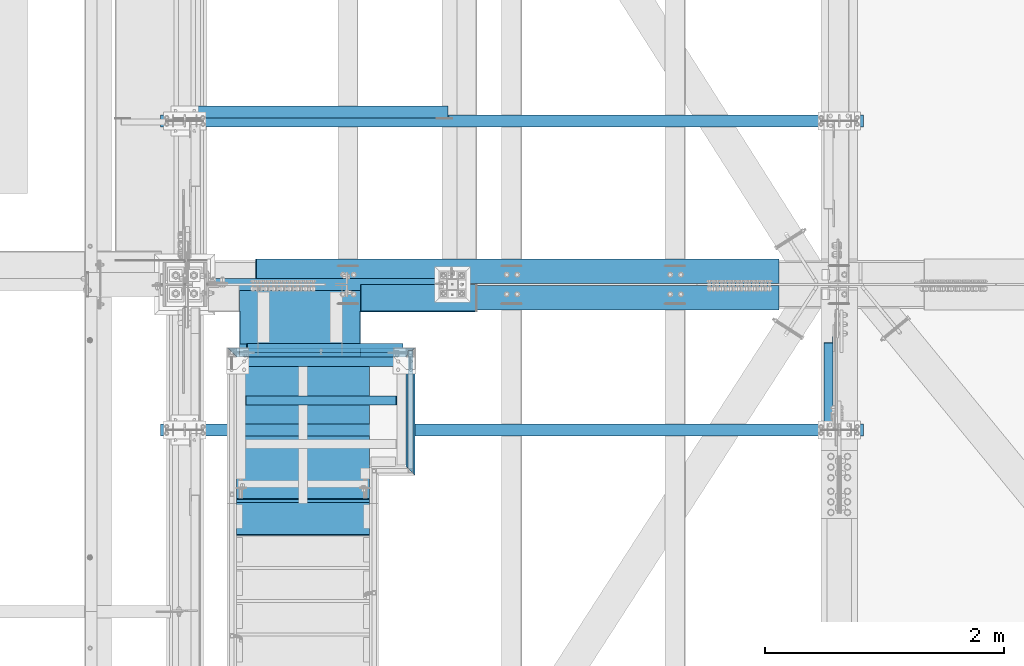
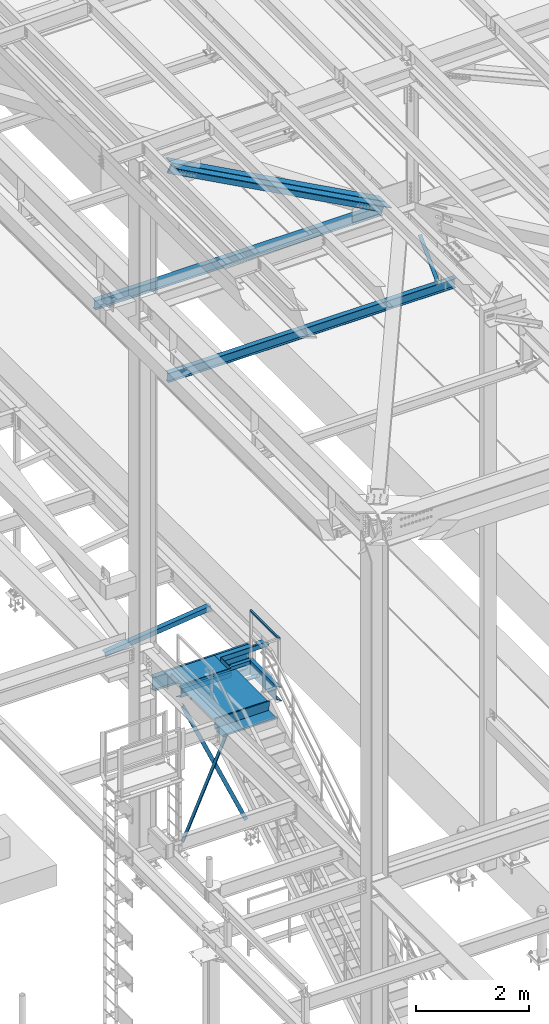
# One storey, part 1805 of 3843: 14 beams, 5 members, 12 elements without a shape of their own.
"""IFC2X3 building model written with IfcOpenShell, lengths in millimetres."""

from ifc_helpers import new_model, si_unit, frame, origin_with_axes, place, context, subcontext, project, spatial, faceted_brep, material, type_object, element, aggregate, save


model = new_model("IFC2X3")

# Units and contexts
model_context = context("Model", 3, precision=1e-05, world=origin_with_axes())
body_context = subcontext(model_context, "Body", "Model", "MODEL_VIEW")
ifc_project = project(units=[si_unit("LENGTHUNIT", "METRE", prefix="MILLI"), si_unit("AREAUNIT", "SQUARE_METRE"), si_unit("VOLUMEUNIT", "CUBIC_METRE"), si_unit("MASSUNIT", "GRAM", prefix="KILO"), si_unit("TIMEUNIT", "SECOND"), si_unit("PLANEANGLEUNIT", "RADIAN"), si_unit("SOLIDANGLEUNIT", "STERADIAN"), si_unit("THERMODYNAMICTEMPERATUREUNIT", "DEGREE_CELSIUS"), si_unit("LUMINOUSINTENSITYUNIT", "LUMEN")], contexts=[model_context])

# Site, building, storey
site_placement = place(None, origin_with_axes())
site = spatial("IfcSite", under=ifc_project, at=site_placement, CompositionType="ELEMENT")
building_placement = place(site_placement, origin_with_axes())
building = spatial("IfcBuilding", under=site, at=building_placement, Name="Undefined", CompositionType="ELEMENT")
storey_placement = place(building_placement, origin_with_axes())
storey = spatial("IfcBuildingStorey", under=building, at=storey_placement, Name="Undefined", CompositionType="ELEMENT", Elevation=0.0)

# Assembly, beam
assembly_1_placement = place(storey_placement, origin_with_axes())
assembly_1 = element("IfcElementAssembly", 1, at=assembly_1_placement, inside=storey, Name="STAIR", AssemblyPlace="NOTDEFINED", PredefinedType="RIGID_FRAME")
ifc_material_1 = material(Name="STEEL/A36")
beam_type_1 = type_object("IfcBeamType", Name="L4X4X1/4", PredefinedType="NOTDEFINED")
beam_1_placement = place(assembly_1_placement, frame((38049.2146716981, 33294.7737144015, 33985.2001791512), z_axis=(1.0335007274989e-05, 0.99999999994657, 2.18655972275883e-07), x_axis=(-0.999999999941156, 1.08469999968456e-05, -1.75999998152391e-07)))
beam_1 = element("IfcBeam", 2, at=beam_1_placement, type_object=beam_type_1, material=ifc_material_1, Name="ANGLE", ObjectType="L4X4X1/4", context=body_context, shape_type="Brep", body=[
    faceted_brep([(0.0, 50.8000000000029, -50.8000000000029), (0.0, 50.8000000000029, 50.8000000000029), (1016.0141118011, 50.8000000018874, 50.7999999975145), (1016.01411180086, 50.8000000018874, -50.8000000025495), (0.0, 44.4499999999971, 50.8000000000029), (1016.01411180112, 44.4500000018888, 50.7999999975291), (-3.63797880709171e-12, 44.4499999999971, -44.4500000000007), (1016.01411180089, 44.4500000018888, -44.4500000025291), (-1.45519152283669e-11, -50.8000000000102, -44.4499999999243), (1016.01411180107, -50.7999999981184, -44.4500000023472), (0.0, -50.8000000000029, -50.8000000000029), (1016.01411180105, -50.7999999981184, -50.800000002353)], [[[0, 1, 2, 3]], [[1, 4, 5, 2]], [[4, 6, 7, 5]], [[6, 8, 9, 7]], [[8, 10, 11, 9]], [[10, 0, 3, 11]], [[5, 7, 9, 11, 3, 2]], [[10, 8, 6, 4, 1, 0]]]),
])

assembly_2_placement = place(storey_placement, origin_with_axes())
assembly_2 = element("IfcElementAssembly", 3, at=assembly_2_placement, inside=storey, Name="RAIL", AssemblyPlace="NOTDEFINED", PredefinedType="RIGID_FRAME")
ifc_material_2 = material()
beam_type_2 = type_object("IfcBeamType", Name="HSS1-1/2X1-1/2X1/4", PredefinedType="NOTDEFINED")
beam_2_placement = place(assembly_2_placement, frame((38468.2999999524, 32283.4, 35204.4), z_axis=(0.0, 0.0, -1.0), x_axis=(0.0, 1.0, 0.0)))
beam_2 = element("IfcBeam", 4, at=beam_2_placement, type_object=beam_type_2, material=ifc_material_2, Name="RAIL", ObjectType="HSS1-1/2X1-1/2X1/4", context=body_context, shape_type="Brep", body=[
    faceted_brep([(-12.6999993309546, 12.6999993299978, -12.6999993299978), (12.6999993300014, -12.6999993299978, -12.6999993300014), (1003.29999932997, -12.6999993299978, -12.6999993299978), (1003.29999932997, 12.6999993299978, -12.6999993299978), (12.6999993290483, -12.6999993299978, 12.6999993299978), (977.900000669972, -12.6999993299978, 12.6999993299978), (-12.6999993300014, 12.6999993299978, 12.6999993300014), (977.900000669972, 12.6999993299978, 12.6999993299978), (-19.0499992359546, 19.0499992350015, -19.0499992350015), (-19.0499992350015, 19.0499992350015, 19.0499992350015), (971.550000764972, 19.0499992350015, 19.0499992350015), (1009.64999923497, 19.0499992350015, -19.0499992350015), (19.0499992350015, -19.0499992350015, 19.0499992350015), (971.550000764972, -19.0499992350015, 19.0499992350015), (19.0499992350015, -19.0499992350015, -19.0499992350015), (1009.64999923497, -19.0499992350015, -19.0499992350015)], [[[0, 1, 2, 3]], [[1, 4, 5, 2]], [[4, 6, 7, 5]], [[6, 0, 3, 7]], [[8, 9, 10, 11]], [[9, 12, 13, 10]], [[12, 14, 15, 13]], [[14, 8, 11, 15]], [[13, 15, 11, 10], [5, 7, 3, 2]], [[14, 12, 9, 8], [6, 4, 1, 0]]]),
])
aggregate(assembly_2, [beam_2])

# Beam
beam_type_3 = type_object("IfcBeamType", Name="C12X20.7", PredefinedType="NOTDEFINED")
beam_3_placement = place(assembly_1_placement, frame((38468.3000000001, 32321.5000000018, 34010.6000000007), z_axis=(0.0, 0.0, 1.0), x_axis=(0.0, 1.0, 0.0)))
beam_3 = element("IfcBeam", 5, at=beam_3_placement, type_object=beam_type_3, material=ifc_material_1, Name="STAIR", ObjectType="C12X20.7", context=body_context, shape_type="Brep", body=[
    faceted_brep([(0.0, 38.0999999999985, -152.400000000001), (0.0, 38.0999999999985, 152.400000000001), (914.399999949343, 38.0999999999985, 152.400000000001), (914.399999949343, 38.0999999999985, -152.400000000001), (-76.2000000000153, -38.0999999999985, 152.400000000001), (990.59999994934, -38.0999999999985, 152.400000000001), (-76.2000000000153, -38.0999999999985, 146.047460000002), (990.59999994934, -38.0999999999985, 146.047460000002), (-7.93750000001819, 30.1624999999985, 134.674927499997), (922.337499949343, 30.1624999999985, 134.674927499997), (-7.93750000001819, 30.1624999999985, -134.674927499997), (922.337499949343, 30.1624999999985, -134.674927499997), (-76.2000000000153, -38.0999999999985, -146.047460000002), (990.59999994934, -38.0999999999985, -146.047460000002), (-76.2000000000153, -38.0999999999985, -152.400000000001), (990.59999994934, -38.0999999999985, -152.400000000001)], [[[0, 1, 2, 3]], [[1, 4, 5, 2]], [[4, 6, 7, 5]], [[6, 8, 9, 7]], [[8, 10, 11, 9]], [[10, 12, 13, 11]], [[12, 14, 15, 13]], [[14, 0, 3, 15]], [[5, 7, 9, 11, 13, 15, 3, 2]], [[14, 12, 10, 8, 6, 4, 1, 0]]]),
])

beam_4_placement = place(assembly_1_placement, frame((36931.6, 33274.0, 34010.6), z_axis=(0.0, 0.0, -1.0), x_axis=(1.0, 0.0, 0.0)))
beam_4 = element("IfcBeam", 6, at=beam_4_placement, type_object=beam_type_3, material=ifc_material_1, Name="STRINGER", ObjectType="C12X20.7", context=body_context, shape_type="Brep", body=[
    faceted_brep([(101.602849427349, 30.1624999999985, -134.674927499997), (101.603589870523, -38.1000000054191, -146.047623876773), (101.603589870523, -38.0999999999985, -152.400000000001), (101.602763329305, 38.0999999999985, -152.400000000154), (101.602763329305, 38.1000000179993, -126.999999618623), (101.602849427349, 30.1624999999985, -126.999999618623), (1117.61378472712, 30.1624999999985, -127.000179146016), (1117.61369862908, 38.100000000406, -127.000179146016), (1117.61664503242, 38.0999999999985, -152.400000000045), (1117.61747157364, -38.0999999999985, -152.400000000001), (1117.61673486648, -38.100000059625, -146.049262607783), (1117.61467499894, 30.1624999999985, -134.674927499997), (85.1802562370649, 38.0999999999985, 152.400000000824), (8.98025623706781, -38.0999999999985, 152.400000000001), (1565.81974376273, -38.0999999999985, 152.400000000001), (1489.61974376273, 38.0999999999985, 152.400000000009), (0.0, -38.0999999999985, 146.047460000002), (82.5500001095643, 38.1000000488275, 150.561442681494), (71.7098720274371, 33.6098720274313, 146.118334762788), (82.5500001095643, 38.1000000002969, -150.540128054214), (71.7098720274371, 33.6098720274313, -146.050000000207), (85.180256239626, 38.0999999999985, -152.400000000162), (8.98025623962167, -38.0999999999985, -152.400000000001), (0.0, -38.0999999999985, -146.047460000002), (68.2625000000044, 30.1624999999985, -134.674927499997), (68.2625000000044, 30.1624999999985, 134.674927499997), (1506.53750004886, 30.1624999999985, 134.674927499997), (1574.7999999674, -38.1000000814529, 146.122772600233), (1503.09012793125, 33.6098719574074, 146.122772600233), (1492.2499998701, 38.0999999999985, 150.561442705031), (1503.09012800965, 33.6098720357986, -146.050000000207), (1492.2499998701, 38.0999999999985, -150.540128068023), (1574.79999996484, -38.1000000840213, -146.050000000207), (1565.81974375927, -38.0999999999985, -152.400000000001), (1489.61974375926, 38.0999999999985, -152.400000000001), (1506.53750004886, 30.1624999999985, -134.674927499997)], [[[0, 1, 2, 3, 4, 5]], [[6, 7, 8, 9, 10, 11]], [[5, 4, 7, 6]], [[12, 13, 14, 15]], [[16, 13, 12, 17, 18]], [[18, 17, 19, 20]], [[21, 22, 23, 20, 19]], [[24, 25, 16, 18, 20, 23]], [[16, 25, 26, 27]], [[13, 16, 27, 14]], [[15, 14, 27, 28, 29]], [[29, 28, 30, 31]], [[32, 33, 34, 31, 30]], [[28, 27, 26, 35, 32, 30]], [[32, 35, 11, 10]], [[33, 32, 10, 9]], [[34, 33, 9, 8]], [[3, 21, 19, 17, 12, 15, 29, 31, 34, 8, 7, 4]], [[22, 21, 3, 2]], [[23, 22, 2, 1]], [[24, 23, 1, 0]], [[35, 26, 25, 24, 0, 5, 6, 11]]]),
])

# Assembly, beam
assembly_3_placement = place(storey_placement, origin_with_axes())
assembly_3 = element("IfcElementAssembly", 7, at=assembly_3_placement, inside=storey, Name="ANGLE", AssemblyPlace="NOTDEFINED", PredefinedType="RIGID_FRAME")
ifc_material_3 = material(Name="STEEL/A572-50")
beam_type_4 = type_object("IfcBeamType", Name="L4X4X3/8", PredefinedType="NOTDEFINED")
beam_5_placement = place(assembly_3_placement, frame((38788.5093206542, 35292.307812, 33960.1419503901), z_axis=(0.0, 1.0, 0.0), x_axis=(-0.993268693078032, 0.0, -0.115833084009098)))
beam_5 = element("IfcBeam", 8, at=beam_5_placement, type_object=beam_type_4, material=ifc_material_3, Name="ANGLE", ObjectType="L4X4X3/8", context=body_context, shape_type="Brep", body=[
    faceted_brep([(0.0, 50.8000000000029, -50.8000000000029), (0.0, 50.8000000000029, 50.8000000000029), (2192.8104802954, 50.7999999940694, 50.8000000000029), (2192.8104802954, 50.7999999940694, -50.8000000000029), (0.0, 41.2750000000015, 50.8000000000029), (2192.81048029537, 41.2749999940788, 50.8000000000029), (0.0, 41.2749999999942, -41.2750000000015), (2192.81048029537, 41.2749999940788, -41.2750000000015), (0.0, -50.8000000000029, -41.2750000000015), (2192.81048029512, -50.8000000058528, -41.2750000000015), (0.0, -50.8000000000029, -50.8000000000029), (2192.81048029512, -50.8000000058528, -50.8000000000029)], [[[0, 1, 2, 3]], [[1, 4, 5, 2]], [[4, 6, 7, 5]], [[6, 8, 9, 7]], [[8, 10, 11, 9]], [[10, 0, 3, 11]], [[5, 7, 9, 11, 3, 2]], [[10, 8, 6, 4, 1, 0]]]),
])
aggregate(assembly_3, [beam_5])

# Beam
beam_type_5 = type_object("IfcBeamType", Name="L3X3X1/4", PredefinedType="NOTDEFINED")
beam_6_placement = place(assembly_1_placement, frame((37014.1499998894, 32871.8333333334, 34048.7000000045), z_axis=(0.0, -1.0, 0.0), x_axis=(1.0, 0.0, 0.0)))
beam_6 = element("IfcBeam", 9, at=beam_6_placement, type_object=beam_type_5, material=ifc_material_1, Name="ANGLE", ObjectType="L3X3X1/4", context=body_context, shape_type="Brep", body=[
    faceted_brep([(1339.8500002734, 31.75, 38.0999999999985), (1339.8500002734, 31.75, -31.75), (1339.8500002734, 31.7499999999927, -38.0999999999985), (1333.5000002728, 38.0999999999985, -38.0999999999985), (1333.5000002728, 38.0999999999985, 38.0999999999985), (1397.0000002734, 31.75, -31.75), (1397.0000002734, 31.7499999999927, -38.0999999999985), (1409.7000002734, 19.0499999999884, -31.75), (1409.70000020599, 19.0499999999884, -38.0999999999985), (76.2000000006228, 38.0999999999985, 38.0999999999985), (76.2000000006228, 38.0999999999985, -38.0999999999985), (69.8500000000349, 31.7499999999927, -38.0999999999985), (69.8500000000349, 31.75, -31.75), (69.8500000000349, 31.75, 38.0999999999985), (12.7000000000262, 31.7499999999927, -38.0999999999985), (12.7000000000262, 31.75, -31.75), (0.0, 19.0499999999884, -38.0999999999985), (0.0, 19.0500000000029, -31.75), (0.0, -38.0999999999985, -38.0999999999985), (0.0, -38.0999999999985, -31.75), (1409.70000020599, -38.0999999999985, -38.0999999999985), (1409.70000020599, -38.0999999999985, -31.75)], [[[0, 1, 2, 3, 4]], [[5, 6, 2, 1]], [[7, 8, 6, 5]], [[9, 10, 11, 12, 13]], [[12, 11, 14, 15]], [[15, 14, 16, 17]], [[18, 19, 17, 16]], [[19, 18, 20, 21]], [[1, 12, 15, 17, 19, 21, 7, 5]], [[13, 12, 1, 0]], [[9, 13, 0, 4]], [[10, 9, 4, 3]], [[20, 18, 16, 14, 11, 10, 3, 2, 6, 8]], [[21, 20, 8, 7]]]),
])

beam_7_placement = place(assembly_1_placement, frame((37096.6999999848, 33197.8, 34048.7000000047), z_axis=(0.0, -1.0, 0.0), x_axis=(1.0, 0.0, 0.0)))
beam_7 = element("IfcBeam", 10, at=beam_7_placement, type_object=beam_type_5, material=ifc_material_1, Name="ANGLE", ObjectType="L3X3X1/4", context=body_context, shape_type="Brep", body=[
    faceted_brep([(0.0, 38.0999999999985, -38.0999999999985), (0.0, 38.0999999999985, 38.0999999999985), (1244.59999996299, 38.0999999999985, 38.0999999999985), (1244.59999996299, 38.0999999999985, -38.0999999999985), (0.0, 31.75, 38.0999999999985), (1244.59999996299, 31.75, 38.0999999999985), (0.0, 31.75, -31.75), (1244.59999996299, 31.75, -31.75), (0.0, -38.0999999999985, -31.75), (1244.59999996299, -38.0999999999985, -31.75), (0.0, -38.0999999999985, -38.0999999999985), (1244.59999996299, -38.0999999999985, -38.0999999999985)], [[[0, 1, 2, 3]], [[1, 4, 5, 2]], [[4, 6, 7, 5]], [[6, 8, 9, 7]], [[8, 10, 11, 9]], [[10, 0, 3, 11]], [[5, 7, 9, 11, 3, 2]], [[10, 8, 6, 4, 1, 0]]]),
])

ifc_material_4 = material(Name="STEEL/ASTM A1011")
beam_type_6 = type_object("IfcBeamType", PredefinedType="NOTDEFINED")
beam_8_placement = place(assembly_1_placement, frame((37566.5999999524, 33229.55, 34088.3875000056), z_axis=(1.0, 0.0, 0.0), x_axis=(0.0, -1.0, 0.0)))
beam_8 = element("IfcBeam", 11, at=beam_8_placement, type_object=beam_type_6, material=ifc_material_4, Name="PAN", context=body_context, shape_type="Brep", body=[
    faceted_brep([(0.0, -1.58750000000146, -558.799999999999), (0.0, -1.58750000000146, 558.799999999999), (0.0, 1.58750000000146, 558.799999999999), (0.0, 1.58750000000146, -558.799999999999), (1201.7339030759, 1.58750000000146, 558.800000000003), (1201.7339030759, 1.58750000000146, -558.800000000003), (1199.02449805333, -1.58750000000146, -558.800000000003), (1199.02449805333, -1.58750000000146, 558.800000000003), (1207.65808361649, -35.6143980153938, 558.800000000003), (1207.65808361649, -35.6143980153938, -558.800000000003), (1204.52259067936, -36.1137065785078, 558.800000000003), (1204.52259067936, -36.1137065785078, -558.800000000003)], [[[0, 1, 2, 3]], [[3, 2, 4, 5]], [[1, 0, 6, 7]], [[5, 4, 8, 9]], [[4, 2, 1, 7, 10, 8]], [[7, 6, 11, 10]], [[6, 0, 3, 5, 9, 11]], [[10, 11, 9, 8]]]),
])

# Assembly, beam
assembly_4_placement = place(storey_placement, origin_with_axes())
assembly_4 = element("IfcElementAssembly", 12, at=assembly_4_placement, inside=storey, Name="BENT_PLATE", AssemblyPlace="NOTDEFINED", PredefinedType="RIGID_FRAME")
beam_type_7 = type_object("IfcBeamType", PredefinedType="NOTDEFINED")
beam_9_placement = place(assembly_4_placement, frame((37036.3781765714, 33544.6457686373, 34137.5995709562), z_axis=(0.0, -1.0, 0.0), x_axis=(-0.000134551999977022, 4.9999291933285e-09, -0.99999999094788)))
beam_9 = element("IfcBeam", 13, at=beam_9_placement, type_object=beam_type_7, material=ifc_material_1, Name="BENT_PLATE", context=body_context, shape_type="Brep", body=[
    faceted_brep([(95.0515616263656, -3.17500003349414, -78.60422611596), (95.0507072211622, 3.17499996651168, -78.60422611596), (95.0507060470045, 3.17499996651168, -300.831555376404), (95.0515604522152, -3.17500003349414, -300.831555376899), (-4.57958012702875e-05, -3.17500000000291, -78.6042807721533), (-4.57935748272575e-05, 3.17500000000291, -78.6042807716585), (94.9157098919968, 1006.48470895541, -78.6042261166367), (94.914855487179, 1012.83470607413, -78.604226116644), (94.9148553958221, 1012.82665716737, -300.868181490223), (94.9157098272408, 1006.47646236626, -300.867949499006), (-0.135806611760927, 1006.47191982081, -78.6042807721024), (-0.136661017080769, 1012.82191976749, -78.6042807721024), (95.2602003469292, 3.17499996643892, 300.831444501651), (0.000175264940480702, 3.17500000000291, 300.831499999942), (0.000175262699485756, -3.17500000000291, 300.831499999949), (101.611054805304, -3.1750000358079, 300.831440801652), (101.599251117746, 3.69761083082994, 300.831307321962), (95.2492511752207, 3.69675642579386, 300.831311021459), (95.2489035747858, 3.67500142122299, -300.831688585131), (95.2380918869312, 3.17499996645347, -300.831555485573), (101.588946345313, -3.17500003579335, -300.831559185564), (101.598903517312, 3.67585582625907, -300.831692284628), (101.46312018871, 1012.8272052638, -300.868181225196), (101.463467695401, 1012.84965692687, 300.794818356211), (94.6136255509409, 1006.49838688433, 300.795047707747), (95.1143221580423, 1006.49880258345, 300.795051659297), (94.612771145752, 1012.84838682271, 300.794818104165), (-0.13688112750242, 1012.83563806561, 300.794763595601), (-0.136026722313545, 1006.48563812723, 300.79499319919), (95.1139746513509, 1006.47635092038, -300.86794792211)], [[[0, 1, 2, 3]], [[4, 5, 1, 0]], [[6, 7, 8, 9]], [[10, 11, 7, 6]], [[12, 13, 14, 15, 16, 17]], [[18, 19, 17]], [[12, 17, 19]], [[13, 12, 19, 2, 1, 5]], [[14, 13, 5, 4]], [[20, 15, 14, 4, 0, 3]], [[20, 21, 15]], [[16, 15, 21]], [[16, 21, 22, 23]], [[24, 25, 17, 16, 23, 26, 27, 28]], [[18, 17, 25, 29]], [[22, 21, 20, 3, 2, 19, 18, 29, 9, 8]], [[27, 26, 23, 22, 8, 7, 11]], [[28, 27, 11, 10]], [[29, 25, 24, 28, 10, 6, 9]]]),
])
aggregate(assembly_4, [beam_9])

assembly_5_placement = place(storey_placement, origin_with_axes())
assembly_5 = element("IfcElementAssembly", 14, at=assembly_5_placement, inside=storey, Name="BEAM", AssemblyPlace="NOTDEFINED", PredefinedType="RIGID_FRAME")
beam_type_8 = type_object("IfcBeamType", PredefinedType="NOTDEFINED")
beam_10_placement = place(assembly_5_placement, frame((38536.5625, 33845.5, 34039.175), z_axis=(-1.0, 0.0, 0.0), x_axis=(0.0, -1.0, 0.0)))
beam_10 = element("IfcBeam", 15, at=beam_10_placement, type_object=beam_type_8, material=ifc_material_1, Name="BENT_PLATE", context=body_context, shape_type="Brep", body=[
    faceted_brep([(225.425005874356, 4.77157300338149e-08, 487.362500000003), (222.250006103517, 3.17500000000291, 484.187500432636), (0.0, 3.17500000000291, 484.187500047701), (0.0, 4.77157300338149e-08, 487.362500000003), (225.424999567396, 98.4250002034532, 487.362500000003), (222.250000000007, 98.4250000000029, 484.187500432636), (222.250006103517, 3.17500000000291, -487.362500000003), (0.0, 3.17500000000291, -487.362500000003), (0.0, 3.17500000000291, -347.662500000006), (63.5000000000146, 3.17500000000291, -347.662499999991), (63.5, 3.17500000000291, -220.662499999999), (0.0, 3.17500000000291, -220.662499999999), (63.5000000000146, -3.17500000000291, -347.662499999991), (0.0, -3.17500000000291, -347.662500000006), (63.5, -3.17500000000291, -220.662499999999), (0.0, -3.17500000000291, -220.662499999999), (228.600006510424, -3.17500000000291, 487.362500000003), (228.600006510424, -3.17500000000291, -487.362500000003), (228.600000000013, 98.4250004069036, -487.362500000003), (228.600000000013, 98.4250004069036, 487.362500000003), (0.0, -3.17500000000291, 487.362500000003), (222.250000000007, 98.4250000000029, -487.362500000003), (0.0, -3.17500000000291, -487.362500000003)], [[[0, 1, 2, 3]], [[4, 5, 1, 0]], [[6, 7, 8, 9, 10, 11, 2, 1]], [[12, 9, 8, 13]], [[14, 10, 9, 12]], [[15, 11, 10, 14]], [[16, 17, 18, 19]], [[20, 16, 19, 4, 0, 3]], [[21, 6, 1, 5]], [[19, 18, 21, 5, 4]], [[17, 22, 7, 6, 21, 18]], [[7, 22, 13, 8]], [[11, 15, 20, 3, 2]], [[13, 22, 17, 16, 20, 15, 14, 12]]]),
])

# Assembly, member
assembly_6_placement = place(storey_placement, origin_with_axes())
assembly_6 = element("IfcElementAssembly", 16, at=assembly_6_placement, inside=storey, Name="ANGLE", AssemblyPlace="NOTDEFINED", PredefinedType="RIGID_FRAME")
member_type_1 = type_object("IfcMemberType", Name="L3X3X3/8", PredefinedType="NOTDEFINED")
member_1_placement = place(assembly_6_placement, frame((38468.3, 33312.1, 30492.7), z_axis=(0.0, 1.0, 0.0), x_axis=(-0.407740875865198, 0.0, 0.913097682698123)))
member_1 = element("IfcMember", 17, at=member_1_placement, type_object=member_type_1, material=ifc_material_1, Name="ANGLE", ObjectType="L3X3X3/8", context=body_context, shape_type="Brep", body=[
    faceted_brep([(241.057562605316, 38.099999999351, -38.0999999999985), (241.057562605316, 38.099999999351, 38.0999999999985), (3434.31591280142, 38.0999999900814, 38.0999999999985), (3434.31591280142, 38.0999999900814, -38.0999999999985), (241.05756260536, 28.5749999993423, 38.0999999999985), (3434.31591280147, 28.5749999900727, 38.0999999999985), (241.05756260536, 28.5749999993423, -28.5749999999971), (3434.31591280147, 28.5749999900727, -28.5749999999971), (241.057562605682, -38.1000000007407, -28.5749999999971), (3434.31591280179, -38.1000000100103, -28.5749999999971), (241.057562605682, -38.1000000007407, -38.0999999999985), (3434.31591280179, -38.1000000100103, -38.0999999999985)], [[[0, 1, 2, 3]], [[1, 4, 5, 2]], [[4, 6, 7, 5]], [[6, 8, 9, 7]], [[8, 10, 11, 9]], [[10, 0, 3, 11]], [[5, 7, 9, 11, 3, 2]], [[10, 8, 6, 4, 1, 0]]]),
])
aggregate(assembly_6, [member_1])

assembly_7_placement = place(storey_placement, origin_with_axes())
assembly_7 = element("IfcElementAssembly", 18, at=assembly_7_placement, inside=storey, Name="ANGLE", AssemblyPlace="NOTDEFINED", PredefinedType="RIGID_FRAME")
member_2_placement = place(assembly_7_placement, frame((36969.6999999994, 33235.9, 30492.7000000006), z_axis=(0.0, -1.0, 0.0), x_axis=(0.407740875865196, 0.0, 0.913097682698123)))
member_2 = element("IfcMember", 19, at=member_2_placement, type_object=member_type_1, material=ifc_material_1, Name="ANGLE", ObjectType="L3X3X3/8", context=body_context, shape_type="Brep", body=[
    faceted_brep([(241.057562605316, 38.099999999351, -38.0999999999985), (241.057562605316, 38.099999999351, 38.0999999999985), (3434.31591280142, 38.0999999900814, 38.0999999999985), (3434.31591280142, 38.0999999900814, -38.0999999999985), (241.05756260536, 28.5749999993423, 38.0999999999985), (3434.31591280147, 28.5749999900727, 38.0999999999985), (241.05756260536, 28.5749999993423, -28.5749999999971), (3434.31591280147, 28.5749999900727, -28.5749999999971), (241.057562605682, -38.1000000007407, -28.5749999999971), (3434.31591280179, -38.1000000100103, -28.5749999999971), (241.057562605682, -38.1000000007407, -38.0999999999985), (3434.31591280179, -38.1000000100103, -38.0999999999985)], [[[0, 1, 2, 3]], [[1, 4, 5, 2]], [[4, 6, 7, 5]], [[6, 8, 9, 7]], [[8, 10, 11, 9]], [[10, 0, 3, 11]], [[5, 7, 9, 11, 3, 2]], [[10, 8, 6, 4, 1, 0]]]),
])
aggregate(assembly_7, [member_2])

# Beam
beam_type_9 = type_object("IfcBeamType", PredefinedType="NOTDEFINED")
beam_11_placement = place(assembly_1_placement, frame((37566.5999999524, 32042.099999987, 34136.0125000056), z_axis=(1.0, 0.0, 0.0), x_axis=(0.0, -1.0, 0.0)))
beam_11 = element("IfcBeam", 20, at=beam_11_placement, type_object=beam_type_9, material=ifc_material_4, Name="TREAD", context=body_context, shape_type="Brep", body=[
    faceted_brep([(0.0, -1.58750000000146, -558.799999999999), (0.0, -1.58750000000146, 558.799999999999), (0.0, 1.58750000000146, 558.799999999999), (0.0, 1.58750000000146, -558.799999999999), (21.7283948539116, 1.58750000000146, 558.800000000003), (21.7283948539116, 1.58750000000146, -558.800000000003), (25.3999999999942, -1.58750000000146, -558.799999999999), (25.3999999999942, -1.58750000000146, 558.799999999999), (-11.0799384794227, 226.55892857143, 558.800000000003), (-11.0799384794227, 226.55892857143, -558.800000000003), (-7.40833333332557, 223.383928571428, -558.800000000003), (-7.40833333332557, 223.383928571428, 558.800000000003), (293.720061520566, 226.55892857143, 558.800000000003), (293.720061520566, 226.55892857143, -558.800000000003), (290.974498041134, 223.383928571428, -558.800000000003), (290.974498041134, 223.383928571428, 558.800000000003), (299.614357882056, 186.140896378427, 558.800000000003), (299.614357882056, 186.140896378427, -558.800000000003), (296.472590667174, 185.682721992918, 558.800000000003), (296.472590667174, 185.682721992918, -558.800000000003)], [[[0, 1, 2, 3]], [[3, 2, 4, 5]], [[1, 0, 6, 7]], [[5, 4, 8, 9]], [[7, 6, 10, 11]], [[9, 8, 12, 13]], [[11, 10, 14, 15]], [[13, 12, 16, 17]], [[12, 8, 4, 2, 1, 7, 11, 15, 18, 16]], [[15, 14, 19, 18]], [[14, 10, 6, 0, 3, 5, 9, 13, 17, 19]], [[18, 19, 17, 16]]]),
])

aggregate(assembly_1, [beam_3, beam_1, beam_6, beam_7, beam_8, beam_4, beam_11])

# Assembly, member
assembly_8_placement = place(storey_placement, origin_with_axes())
assembly_8 = element("IfcElementAssembly", 21, at=assembly_8_placement, inside=storey, Name="ANGLE", AssemblyPlace="NOTDEFINED", PredefinedType="RIGID_FRAME")
member_type_2 = type_object("IfcMemberType", Name="L3X3X1/4", PredefinedType="NOTDEFINED")
member_3_placement = place(assembly_8_placement, frame((41973.5, 32621.8467459768, 41295.9467460364), z_axis=(5.70000238222118e-08, 0.707106781186546, -0.707106781186546), x_axis=(0.0, 0.707106781186548, 0.707106781186548)))
member_3 = element("IfcMember", 22, at=member_3_placement, type_object=member_type_2, material=ifc_material_3, Name="ANGLE", ObjectType="L3X3X1/4", context=body_context, shape_type="Brep", body=[
    faceted_brep([(83.0012806675732, 38.0999999999985, -38.0999999999058), (83.0012806675732, -38.0999999999985, -38.0999999999058), (83.0012806675804, -38.0999999999985, -31.7499999999254), (83.0012806675804, 31.75, -31.7499999999254), (83.0012806675804, 31.75, 38.0999999999058), (83.0012806675804, 38.0999999999985, 38.0999999999058), (1073.60128066748, 31.75, 38.0999999999094), (1073.60128066748, 38.0999999999985, 38.0999999999094), (1073.60128066748, 38.0999999999985, -38.0999999999094), (1073.60128066748, -38.0999999999985, -38.0999999999094), (1073.60128066748, -38.0999999999985, -31.7499999999218), (1073.60128066748, 31.75, -31.7499999999218)], [[[0, 1, 2, 3, 4, 5]], [[5, 4, 6, 7]], [[0, 5, 7, 8]], [[1, 0, 8, 9]], [[2, 1, 9, 10]], [[3, 2, 10, 11]], [[4, 3, 11, 6]], [[10, 9, 8, 7, 6, 11]]]),
])
aggregate(assembly_8, [member_3])

# Assembly, beam
assembly_9_placement = place(storey_placement, origin_with_axes())
assembly_9 = element("IfcElementAssembly", 23, at=assembly_9_placement, inside=storey, Name="BEAM", AssemblyPlace="NOTDEFINED", PredefinedType="RIGID_FRAME")
ifc_material_5 = material(Name="STEEL/A992")
beam_type_10 = type_object("IfcBeamType", Name="W8X13", PredefinedType="NOTDEFINED")
beam_12_placement = place(assembly_9_placement, frame((36372.8, 32626.3, 41402.0), z_axis=(0.0, 0.0, 1.0), x_axis=(1.0, 0.0, 0.0)))
beam_12 = element("IfcBeam", 24, at=beam_12_placement, type_object=beam_type_10, material=ifc_material_5, Name="BEAM", ObjectType="W8X13", context=body_context, shape_type="Brep", body=[
    faceted_brep([(0.0, 50.7999999999993, -101.599999999999), (0.0, 50.7999999999993, -95.25), (5892.8, 50.7999999999993, -95.25), (5892.8, 50.7999999999993, -101.599999999999), (0.0, 3.17499999999927, -95.25), (5892.8, 3.17499999999927, -95.25), (-2.44140610448085e-05, 3.17500000000291, 95.2499999999927), (5892.8, 3.17499999999927, 95.25), (0.0, 50.7999999999993, 95.25), (5892.8, 50.7999999999993, 95.25), (0.0, 50.7999999999993, 101.599999999999), (5892.8, 50.7999999999993, 101.599999999999), (0.0, -50.7999999999993, 101.599999999999), (5892.8, -50.7999999999993, 101.599999999999), (0.0, -50.7999999999993, 95.25), (5892.8, -50.7999999999993, 95.25), (0.0, -3.17499999999927, 95.25), (5892.8, -3.17499999999927, 95.25), (0.0, -3.17499999999927, -95.25), (5892.8, -3.17499999999927, -95.25), (0.0, -50.7999999999993, -95.25), (5892.8, -50.7999999999993, -95.25), (0.0, -50.7999999999993, -101.599999999999), (5892.8, -50.7999999999993, -101.599999999999)], [[[0, 1, 2, 3]], [[1, 4, 5, 2]], [[4, 6, 7, 5]], [[6, 8, 9, 7]], [[8, 10, 11, 9]], [[10, 12, 13, 11]], [[12, 14, 15, 13]], [[14, 16, 17, 15]], [[16, 18, 19, 17]], [[18, 20, 21, 19]], [[20, 22, 23, 21]], [[22, 0, 3, 23]], [[5, 7, 9, 11, 13, 15, 17, 19, 21, 23, 3, 2]], [[22, 20, 18, 16, 14, 12, 10, 8, 6, 4, 1, 0]]]),
])
aggregate(assembly_9, [beam_12])

assembly_10_placement = place(storey_placement, origin_with_axes())
assembly_10 = element("IfcElementAssembly", 25, at=assembly_10_placement, inside=storey, Name="BEAM", AssemblyPlace="NOTDEFINED", PredefinedType="RIGID_FRAME")
beam_13_placement = place(assembly_10_placement, frame((36372.8, 35217.1, 41402.0), z_axis=(0.0, 0.0, 1.0), x_axis=(1.0, 0.0, 0.0)))
beam_13 = element("IfcBeam", 26, at=beam_13_placement, type_object=beam_type_10, material=ifc_material_5, Name="BEAM", ObjectType="W8X13", context=body_context, shape_type="Brep", body=[
    faceted_brep([(0.0, 50.7999999999993, -101.599999999999), (0.0, 50.7999999999993, -95.25), (5892.8, 50.7999999999993, -95.25), (5892.8, 50.7999999999993, -101.599999999999), (0.0, 3.17499999999927, -95.25), (5892.8, 3.17499999999927, -95.25), (-2.44140610448085e-05, 3.17500000000291, 95.2499999999927), (5892.8, 3.17499999999927, 95.25), (0.0, 50.7999999999993, 95.25), (5892.8, 50.7999999999993, 95.25), (0.0, 50.7999999999993, 101.599999999999), (5892.8, 50.7999999999993, 101.599999999999), (0.0, -50.7999999999993, 101.599999999999), (5892.8, -50.7999999999993, 101.599999999999), (0.0, -50.7999999999993, 95.25), (5892.8, -50.7999999999993, 95.25), (0.0, -3.17499999999927, 95.25), (5892.8, -3.17499999999927, 95.25), (0.0, -3.17499999999927, -95.25), (5892.8, -3.17499999999927, -95.25), (0.0, -50.7999999999993, -95.25), (5892.8, -50.7999999999993, -95.25), (0.0, -50.7999999999993, -101.599999999999), (5892.8, -50.7999999999993, -101.599999999999)], [[[0, 1, 2, 3]], [[1, 4, 5, 2]], [[4, 6, 7, 5]], [[6, 8, 9, 7]], [[8, 10, 11, 9]], [[10, 12, 13, 11]], [[12, 14, 15, 13]], [[14, 16, 17, 15]], [[16, 18, 19, 17]], [[18, 20, 21, 19]], [[20, 22, 23, 21]], [[22, 0, 3, 23]], [[5, 7, 9, 11, 13, 15, 17, 19, 21, 23, 3, 2]], [[22, 20, 18, 16, 14, 12, 10, 8, 6, 4, 1, 0]]]),
])
aggregate(assembly_10, [beam_13])

# Assembly, member
assembly_11_placement = place(storey_placement, origin_with_axes())
assembly_11 = element("IfcElementAssembly", 27, at=assembly_11_placement, inside=storey, Name="ANGLE", AssemblyPlace="NOTDEFINED", PredefinedType="RIGID_FRAME")
member_type_3 = type_object("IfcMemberType", Name="L8X8X1/2", PredefinedType="NOTDEFINED")
member_4_placement = place(assembly_11_placement, frame((36576.0, 33956.625, 45221.4789169382), z_axis=(-0.476342622833741, 0.0, -0.879259748693111), x_axis=(0.879259748693112, 0.0, -0.47634262283374)))
member_4 = element("IfcMember", 28, at=member_4_placement, type_object=member_type_3, material=ifc_material_3, Name="ANGLE", ObjectType="L8X8X1/2", context=body_context, shape_type="Brep", body=[
    faceted_brep([(626.661351328785, 101.599999999999, -101.600000000159), (626.661351328788, 101.599999999999, 101.599999999009), (5612.94860472577, 101.599999999999, 101.599999994498), (5612.94860472577, 101.599999999999, -101.60000000467), (626.661351328788, 88.9000000000015, 101.599999999009), (5612.94860472577, 88.9000000000015, 101.599999994498), (626.661351328788, 88.9000000000015, -88.9000000002125), (5612.94860472577, 88.9000000000015, -88.9000000047163), (626.661351328788, -101.599999999999, -88.9000000002125), (5612.94860472577, -101.599999999999, -88.9000000047163), (626.661351328785, -101.599999999999, -101.600000000159), (5612.94860472577, -101.599999999999, -101.60000000467)], [[[0, 1, 2, 3]], [[1, 4, 5, 2]], [[4, 6, 7, 5]], [[6, 8, 9, 7]], [[8, 10, 11, 9]], [[10, 0, 3, 11]], [[5, 7, 9, 11, 3, 2]], [[10, 8, 6, 4, 1, 0]]]),
])
aggregate(assembly_11, [member_4])

assembly_12_placement = place(storey_placement, origin_with_axes())
assembly_12 = element("IfcElementAssembly", 29, at=assembly_12_placement, inside=storey, Name="ANGLE", AssemblyPlace="NOTDEFINED", PredefinedType="RIGID_FRAME")
member_5_placement = place(assembly_12_placement, frame((42062.4, 33734.375, 42249.1989165259), z_axis=(-0.476342622833741, 0.0, -0.879259748693111), x_axis=(-0.879259748693111, 0.0, 0.476342622833741)))
member_5 = element("IfcMember", 30, at=member_5_placement, type_object=member_type_3, material=ifc_material_3, Name="ANGLE", ObjectType="L8X8X1/2", context=body_context, shape_type="Brep", body=[
    faceted_brep([(626.845731645742, 101.599999999999, -101.599999999024), (626.845731645742, 101.599999999999, 101.600000000151), (5613.13298504273, 101.599999999999, 101.600000004655), (5613.13298504273, 101.599999999999, -101.599999994505), (626.845731645742, 88.9000000000015, 101.600000000151), (5613.13298504273, 88.9000000000015, 101.600000004655), (626.84573164575, 88.9000000000015, -88.8999999990701), (5613.13298504273, 88.9000000000015, -88.8999999945663), (626.84573164575, -101.599999999999, -88.8999999990701), (5613.13298504273, -101.599999999999, -88.8999999945663), (626.845731645742, -101.599999999999, -101.599999999024), (5613.13298504273, -101.599999999999, -101.599999994505)], [[[0, 1, 2, 3]], [[1, 4, 5, 2]], [[4, 6, 7, 5]], [[6, 8, 9, 7]], [[8, 10, 11, 9]], [[10, 0, 3, 11]], [[5, 7, 9, 11, 3, 2]], [[10, 8, 6, 4, 1, 0]]]),
])
aggregate(assembly_12, [member_5])

# Beam
beam_type_11 = type_object("IfcBeamType", Name="W12X14", PredefinedType="NOTDEFINED")
beam_14_placement = place(assembly_5_placement, frame((36576.0, 33845.5, 33885.1875), z_axis=(0.0, 0.0, 1.0), x_axis=(1.0, 0.0, 0.0)))
beam_14 = element("IfcBeam", 31, at=beam_14_placement, type_object=beam_type_11, material=ifc_material_5, Name="BEAM", ObjectType="W12X14", context=body_context, shape_type="Brep", body=[
    faceted_brep([(196.849999999999, -50.8000000000029, -150.8125), (196.849999999999, 50.8000000000029, -150.8125), (2181.225, 50.8000000000029, -150.8125), (2181.225, -50.8000000000029, -150.8125), (196.849999999973, -50.8000000000029, -144.462500000001), (196.849999999999, -2.38125000000582, -144.462500000001), (196.849999999999, -2.38125000000582, 144.462500000001), (196.849999999973, -50.8000000000029, 144.462500000001), (196.849999999999, -50.8000000000029, 150.8125), (196.849999999999, 50.8000000000029, 150.8125), (196.849999999973, 50.8000000000029, 144.462500000001), (196.849999999999, 2.38125000000582, 144.462500000001), (196.849999999999, 2.38125000000582, -144.462500000001), (196.849999999973, 50.8000000000029, -144.462500000001), (2181.225, -50.8000000000029, -144.462500000001), (2181.225, -2.38125000000582, -144.462500000001), (2181.225, -2.38125000000582, 144.462500000001), (2181.225, -50.8000000000029, 144.462500000001), (2181.225, -50.8000000000029, 150.8125), (2181.225, 50.8000000000029, 150.8125), (2181.225, 50.8000000000029, 144.462500000001), (2181.225, 2.38125000000582, 144.462500000001), (2181.225, 2.38125000000582, -144.462500000001), (2181.225, 50.8000000000029, -144.462500000001)], [[[0, 1, 2, 3]], [[0, 4, 5, 6, 7, 8, 9, 10, 11, 12, 13, 1]], [[5, 4, 14, 15]], [[6, 5, 15, 16]], [[7, 6, 16, 17]], [[8, 7, 17, 18]], [[9, 8, 18, 19]], [[10, 9, 19, 20]], [[11, 10, 20, 21]], [[12, 11, 21, 22]], [[13, 12, 22, 23]], [[1, 13, 23, 2]], [[22, 21, 20, 19, 18, 17, 16, 15, 14, 3, 2, 23]], [[4, 0, 3, 14]]]),
])

aggregate(assembly_5, [beam_10, beam_14])

save(model, "model.ifc")
